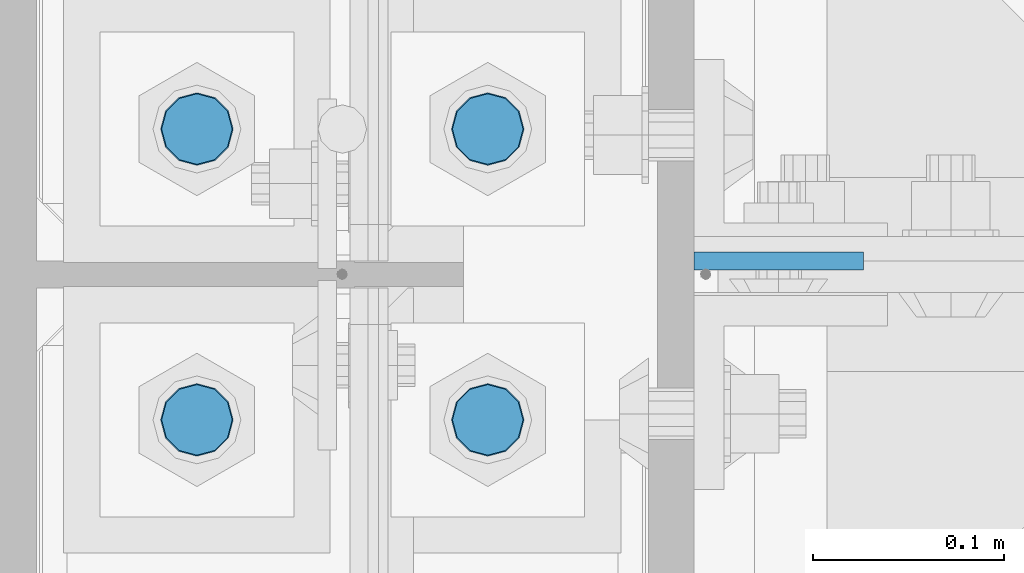
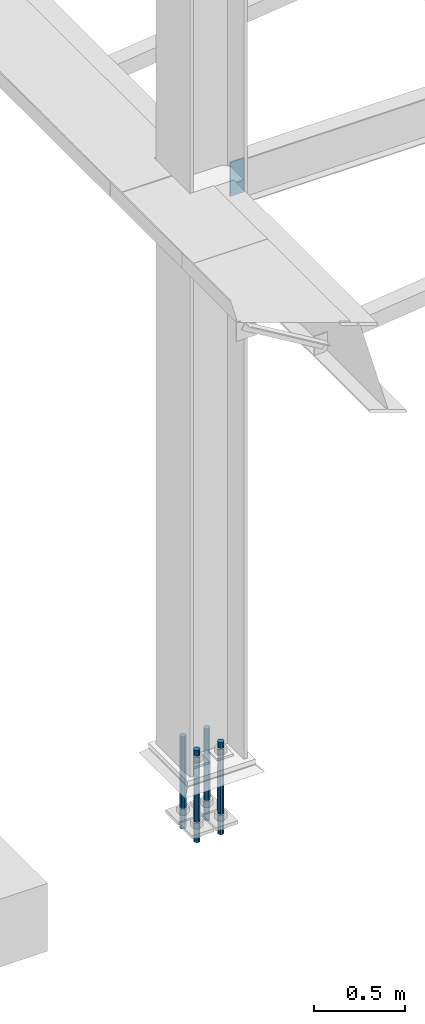
# One storey, part 1513 of 3843: 5 columns, 2 elements without a shape of their own.
"""IFC2X3 building model written with IfcOpenShell, lengths in millimetres."""

from ifc_helpers import new_model, si_unit, frame, origin_with_axes, place, context, subcontext, project, spatial, faceted_brep, material, type_object, element, aggregate, save


model = new_model("IFC2X3")

# Units and contexts
model_context = context("Model", 3, precision=1e-05, world=origin_with_axes())
body_context = subcontext(model_context, "Body", "Model", "MODEL_VIEW")
ifc_project = project(units=[si_unit("LENGTHUNIT", "METRE", prefix="MILLI"), si_unit("AREAUNIT", "SQUARE_METRE"), si_unit("VOLUMEUNIT", "CUBIC_METRE"), si_unit("MASSUNIT", "GRAM", prefix="KILO"), si_unit("TIMEUNIT", "SECOND"), si_unit("PLANEANGLEUNIT", "RADIAN"), si_unit("SOLIDANGLEUNIT", "STERADIAN"), si_unit("THERMODYNAMICTEMPERATUREUNIT", "DEGREE_CELSIUS"), si_unit("LUMINOUSINTENSITYUNIT", "LUMEN")], contexts=[model_context])

# Site, building, storey
site_placement = place(None, origin_with_axes())
site = spatial("IfcSite", under=ifc_project, at=site_placement, CompositionType="ELEMENT")
building_placement = place(site_placement, origin_with_axes())
building = spatial("IfcBuilding", under=site, at=building_placement, Name="Undefined", CompositionType="ELEMENT")
storey_placement = place(building_placement, origin_with_axes())
storey = spatial("IfcBuildingStorey", under=building, at=storey_placement, Name="Undefined", CompositionType="ELEMENT", Elevation=0.0)

# Assembly, column
assembly_1_placement = place(storey_placement, origin_with_axes())
assembly_1 = element("IfcElementAssembly", 1, at=assembly_1_placement, inside=storey, Name="COLUMN", AssemblyPlace="NOTDEFINED", PredefinedType="RIGID_FRAME")
ifc_material_1 = material(Name="STEEL/A572-50")
column_type_1 = type_object("IfcColumnType", PredefinedType="NOTDEFINED")
column_1_placement = place(assembly_1_placement, frame((36804.6, 42209.24375, 33769.3), z_axis=(-1.0, 0.0, 0.0), x_axis=(0.0, 0.0, 1.0)))
column_1 = element("IfcColumn", 2, at=column_1_placement, type_object=column_type_1, material=ifc_material_1, Name="PLATE", context=body_context, shape_type="Brep", body=[
    faceted_brep([(0.0, 4.76249999999709, -44.4500000000007), (0.0, 4.76249999999709, 44.4500000000007), (228.599999999999, 4.76249999999709, 44.4500000000007), (228.599999999999, 4.76249999999709, -44.4500000000007), (0.0, -4.76249999999709, 44.4500000000007), (228.599999999999, -4.76249999999709, 44.4500000000007), (0.0, -4.76249999999709, -44.4500000000007), (228.599999999999, -4.76249999999709, -44.4500000000007)], [[[0, 1, 2, 3]], [[1, 4, 5, 2]], [[4, 6, 7, 5]], [[6, 0, 3, 7]], [[5, 7, 3, 2]], [[6, 4, 1, 0]]]),
])
aggregate(assembly_1, [column_1])

# Assembly, columns
assembly_2_placement = place(storey_placement, origin_with_axes())
assembly_2 = element("IfcElementAssembly", 3, at=assembly_2_placement, inside=storey, Name="TEMPLATE", AssemblyPlace="NOTDEFINED", PredefinedType="RIGID_FRAME")
ifc_material_2 = material(Name="Undefined/F1554-GR.55")
column_type_2 = type_object("IfcColumnType", PredefinedType="NOTDEFINED")
column_2_placement = place(assembly_2_placement, frame((36652.2, 42125.9, 30022.8), z_axis=(1.0, 0.0, 0.0), x_axis=(0.0, 0.0, -1.0)))
column_2 = element("IfcColumn", 4, at=column_2_placement, type_object=column_type_2, material=ifc_material_2, Name="ANCHOR_ROD", context=body_context, shape_type="Brep", body=[
    faceted_brep([(-165.100000000002, -16.0214699700118, 9.25), (-165.100000000002, -9.25, 16.0214699700155), (-165.100000000002, 0.0, 18.5), (-165.100000000002, 9.25, 16.0214699700155), (-165.100000000002, 16.0214699700118, 9.25), (-165.100000000002, 18.5, 0.0), (-165.100000000002, 16.0214699700118, -9.25), (-165.100000000002, 9.25, -16.0214699700155), (-165.100000000002, 0.0, -18.5), (-165.100000000002, -9.25, -16.0214699700155), (-165.100000000002, -16.0214699700118, -9.25), (-165.100000000002, -18.5, 0.0), (0.0, 18.5, 0.0), (0.0, 16.0214699700118, -9.25), (0.0, 9.25, -16.0214699700155), (0.0, 0.0, -18.5), (0.0, -9.25, -16.0214699700155), (0.0, -16.0214699700118, -9.25), (0.0, -18.5, 0.0), (0.0, -16.0214699700118, 9.25), (0.0, -9.25, 16.0214699700155), (0.0, 0.0, 18.5), (0.0, 9.25, 16.0214699700155), (0.0, 16.0214699700118, 9.25), (0.0, -16.4977839420972, 9.52500000000146), (0.0, -9.52500000000146, 16.4977839420972), (0.0, 0.0, 19.0499989999989), (0.0, 9.52500000000146, 16.4977839420972), (0.0, 16.4977839420972, 9.52500000000146), (0.0, 19.0500000000029, 0.0), (0.0, 16.4977839420972, -9.52500000000146), (0.0, 9.52500000000146, -16.4977839420972), (0.0, 0.0, -19.0499989999989), (0.0, -9.52500000000146, -16.4977839420972), (0.0, -16.4977839420972, -9.52500000000146), (0.0, -19.0500000000029, 0.0), (304.799999999999, -19.0499999999993, 0.0), (304.799999999999, -16.4977839420935, 9.52499999999418), (304.799999999999, -9.52500000000146, 16.4977839420899), (304.799987999999, 0.0, 19.0499989999989), (304.799999999999, 9.52500000000146, 16.4977839420899), (304.799999999999, 16.4977839420935, 9.52499999999418), (304.799987792969, 19.0499999999993, 0.0), (304.799999999999, 16.4977839420935, -9.52499999999418), (304.799999999999, 9.52500000000146, -16.4977839420899), (304.799987999999, 0.0, -19.0499989999989), (304.799999999999, -9.52500000000146, -16.4977839420899), (304.799999999999, -16.4977839420935, -9.52499999999418), (304.799999999999, -9.25, 16.0214699700155), (304.799999999999, 0.0, 18.5), (304.799999999999, 9.25, 16.0214699700155), (304.799999999999, 16.0214699700118, 9.25), (304.799999999999, 18.5, 0.0), (304.799999999999, 16.0214699700118, -9.25), (304.799999999999, 9.25, -16.0214699700155), (304.799999999999, 0.0, -18.5), (304.799999999999, -9.25, -16.0214699700155), (304.799999999999, -16.0214699700118, -9.25), (304.799999999999, -18.5, 0.0), (304.799999999999, -16.0214699700118, 9.25), (457.200000000001, -9.25, -16.0214699700155), (457.200000000001, 0.0, -18.5), (457.200000000001, 9.25, -16.0214699700155), (457.200000000001, 16.0214699700118, -9.25), (457.200000000001, 18.5, 0.0), (457.200000000001, 16.0214699700118, 9.25), (457.200000000001, 9.25, 16.0214699700155), (457.200000000001, 0.0, 18.5), (457.200000000001, -9.25, 16.0214699700155), (457.200000000001, -16.0214699700118, 9.25), (457.200000000001, -18.5, 0.0), (457.200000000001, -16.0214699700118, -9.25)], [[[0, 1, 2, 3, 4, 5, 6, 7, 8, 9, 10, 11]], [[6, 5, 12, 13]], [[7, 6, 13, 14]], [[8, 7, 14, 15]], [[9, 8, 15, 16]], [[10, 9, 16, 17]], [[11, 10, 17, 18]], [[0, 11, 18, 19]], [[1, 0, 19, 20]], [[2, 1, 20, 21]], [[3, 2, 21, 22]], [[4, 3, 22, 23]], [[5, 4, 23, 12]], [[24, 25, 26, 27, 28, 29, 30, 31, 32, 33, 34, 35], [22, 21, 20, 19, 18, 17, 16, 15, 14, 13, 12, 23]], [[24, 35, 36, 37]], [[25, 24, 37, 38]], [[26, 25, 38, 39]], [[27, 26, 39, 40]], [[28, 27, 40, 41]], [[29, 28, 41, 42]], [[30, 29, 42, 43]], [[31, 30, 43, 44]], [[32, 31, 44, 45]], [[33, 32, 45, 46]], [[34, 33, 46, 47]], [[35, 34, 47, 36]], [[46, 45, 44, 43, 42, 41, 40, 39, 38, 37, 36, 47], [48, 49, 50, 51, 52, 53, 54, 55, 56, 57, 58, 59]], [[60, 61, 62, 63, 64, 65, 66, 67, 68, 69, 70, 71]], [[68, 67, 49, 48]], [[69, 68, 48, 59]], [[70, 69, 59, 58]], [[71, 70, 58, 57]], [[60, 71, 57, 56]], [[61, 60, 56, 55]], [[62, 61, 55, 54]], [[63, 62, 54, 53]], [[64, 63, 53, 52]], [[65, 64, 52, 51]], [[66, 65, 51, 50]], [[67, 66, 50, 49]]]),
])
column_3_placement = place(assembly_2_placement, frame((36652.2, 42278.3, 30022.8), z_axis=(-1.0, 0.0, 0.0), x_axis=(0.0, 0.0, -1.0)))
column_3 = element("IfcColumn", 5, at=column_3_placement, type_object=column_type_2, material=ifc_material_2, Name="ANCHOR_ROD", context=body_context, shape_type="Brep", body=[
    faceted_brep([(-165.100000000002, -16.0214699700118, 9.25), (-165.100000000002, -9.25, 16.0214699700155), (-165.100000000002, 0.0, 18.5), (-165.100000000002, 9.25, 16.0214699700155), (-165.100000000002, 16.0214699700118, 9.25), (-165.100000000002, 18.5, 0.0), (-165.100000000002, 16.0214699700118, -9.25), (-165.100000000002, 9.25, -16.0214699700155), (-165.100000000002, 0.0, -18.5), (-165.100000000002, -9.25, -16.0214699700155), (-165.100000000002, -16.0214699700118, -9.25), (-165.100000000002, -18.5, 0.0), (0.0, 18.5, 0.0), (0.0, 16.0214699700118, -9.25), (0.0, 9.25, -16.0214699700155), (0.0, 0.0, -18.5), (0.0, -9.25, -16.0214699700155), (0.0, -16.0214699700118, -9.25), (0.0, -18.5, 0.0), (0.0, -16.0214699700118, 9.25), (0.0, -9.25, 16.0214699700155), (0.0, 0.0, 18.5), (0.0, 9.25, 16.0214699700155), (0.0, 16.0214699700118, 9.25), (0.0, -16.4977839420972, 9.52500000000146), (0.0, -9.52500000000146, 16.4977839420972), (0.0, 0.0, 19.0499989999989), (0.0, 9.52500000000146, 16.4977839420972), (0.0, 16.4977839420972, 9.52500000000146), (0.0, 19.0500000000029, 0.0), (0.0, 16.4977839420972, -9.52500000000146), (0.0, 9.52500000000146, -16.4977839420972), (0.0, 0.0, -19.0499989999989), (0.0, -9.52500000000146, -16.4977839420972), (0.0, -16.4977839420972, -9.52500000000146), (0.0, -19.0500000000029, 0.0), (304.799999999999, -19.0499999999993, 0.0), (304.799999999999, -16.4977839420935, 9.52499999999418), (304.799999999999, -9.52500000000146, 16.4977839420899), (304.799987999999, 0.0, 19.0499989999989), (304.799999999999, 9.52500000000146, 16.4977839420899), (304.799999999999, 16.4977839420935, 9.52499999999418), (304.799987792969, 19.0499999999993, 0.0), (304.799999999999, 16.4977839420935, -9.52499999999418), (304.799999999999, 9.52500000000146, -16.4977839420899), (304.799987999999, 0.0, -19.0499989999989), (304.799999999999, -9.52500000000146, -16.4977839420899), (304.799999999999, -16.4977839420935, -9.52499999999418), (304.799999999999, -9.25, 16.0214699700155), (304.799999999999, 0.0, 18.5), (304.799999999999, 9.25, 16.0214699700155), (304.799999999999, 16.0214699700118, 9.25), (304.799999999999, 18.5, 0.0), (304.799999999999, 16.0214699700118, -9.25), (304.799999999999, 9.25, -16.0214699700155), (304.799999999999, 0.0, -18.5), (304.799999999999, -9.25, -16.0214699700155), (304.799999999999, -16.0214699700118, -9.25), (304.799999999999, -18.5, 0.0), (304.799999999999, -16.0214699700118, 9.25), (457.200000000001, -9.25, -16.0214699700155), (457.200000000001, 0.0, -18.5), (457.200000000001, 9.25, -16.0214699700155), (457.200000000001, 16.0214699700118, -9.25), (457.200000000001, 18.5, 0.0), (457.200000000001, 16.0214699700118, 9.25), (457.200000000001, 9.25, 16.0214699700155), (457.200000000001, 0.0, 18.5), (457.200000000001, -9.25, 16.0214699700155), (457.200000000001, -16.0214699700118, 9.25), (457.200000000001, -18.5, 0.0), (457.200000000001, -16.0214699700118, -9.25)], [[[0, 1, 2, 3, 4, 5, 6, 7, 8, 9, 10, 11]], [[6, 5, 12, 13]], [[7, 6, 13, 14]], [[8, 7, 14, 15]], [[9, 8, 15, 16]], [[10, 9, 16, 17]], [[11, 10, 17, 18]], [[0, 11, 18, 19]], [[1, 0, 19, 20]], [[2, 1, 20, 21]], [[3, 2, 21, 22]], [[4, 3, 22, 23]], [[5, 4, 23, 12]], [[24, 25, 26, 27, 28, 29, 30, 31, 32, 33, 34, 35], [22, 21, 20, 19, 18, 17, 16, 15, 14, 13, 12, 23]], [[24, 35, 36, 37]], [[25, 24, 37, 38]], [[26, 25, 38, 39]], [[27, 26, 39, 40]], [[28, 27, 40, 41]], [[29, 28, 41, 42]], [[30, 29, 42, 43]], [[31, 30, 43, 44]], [[32, 31, 44, 45]], [[33, 32, 45, 46]], [[34, 33, 46, 47]], [[35, 34, 47, 36]], [[46, 45, 44, 43, 42, 41, 40, 39, 38, 37, 36, 47], [48, 49, 50, 51, 52, 53, 54, 55, 56, 57, 58, 59]], [[60, 61, 62, 63, 64, 65, 66, 67, 68, 69, 70, 71]], [[68, 67, 49, 48]], [[69, 68, 48, 59]], [[70, 69, 59, 58]], [[71, 70, 58, 57]], [[60, 71, 57, 56]], [[61, 60, 56, 55]], [[62, 61, 55, 54]], [[63, 62, 54, 53]], [[64, 63, 53, 52]], [[65, 64, 52, 51]], [[66, 65, 51, 50]], [[67, 66, 50, 49]]]),
])
column_4_placement = place(assembly_2_placement, frame((36499.8, 42125.9, 30022.8), z_axis=(1.0, 0.0, 0.0), x_axis=(0.0, 0.0, -1.0)))
column_4 = element("IfcColumn", 6, at=column_4_placement, type_object=column_type_2, material=ifc_material_2, Name="ANCHOR_ROD", context=body_context, shape_type="Brep", body=[
    faceted_brep([(-165.100000000002, -16.0214699700118, 9.25), (-165.100000000002, -9.25, 16.0214699700155), (-165.100000000002, 0.0, 18.5), (-165.100000000002, 9.25, 16.0214699700155), (-165.100000000002, 16.0214699700118, 9.25), (-165.100000000002, 18.5, 0.0), (-165.100000000002, 16.0214699700118, -9.25), (-165.100000000002, 9.25, -16.0214699700155), (-165.100000000002, 0.0, -18.5), (-165.100000000002, -9.25, -16.0214699700155), (-165.100000000002, -16.0214699700118, -9.25), (-165.100000000002, -18.5, 0.0), (0.0, 18.5, 0.0), (0.0, 16.0214699700118, -9.25), (0.0, 9.25, -16.0214699700155), (0.0, 0.0, -18.5), (0.0, -9.25, -16.0214699700155), (0.0, -16.0214699700118, -9.25), (0.0, -18.5, 0.0), (0.0, -16.0214699700118, 9.25), (0.0, -9.25, 16.0214699700155), (0.0, 0.0, 18.5), (0.0, 9.25, 16.0214699700155), (0.0, 16.0214699700118, 9.25), (0.0, -16.4977839420972, 9.52500000000146), (0.0, -9.52500000000146, 16.4977839420972), (0.0, 0.0, 19.0499989999989), (0.0, 9.52500000000146, 16.4977839420972), (0.0, 16.4977839420972, 9.52500000000146), (0.0, 19.0500000000029, 0.0), (0.0, 16.4977839420972, -9.52500000000146), (0.0, 9.52500000000146, -16.4977839420972), (0.0, 0.0, -19.0499989999989), (0.0, -9.52500000000146, -16.4977839420972), (0.0, -16.4977839420972, -9.52500000000146), (0.0, -19.0500000000029, 0.0), (304.799999999999, -19.0499999999993, 0.0), (304.799999999999, -16.4977839420935, 9.52499999999418), (304.799999999999, -9.52500000000146, 16.4977839420899), (304.799987999999, 0.0, 19.0499989999989), (304.799999999999, 9.52500000000146, 16.4977839420899), (304.799999999999, 16.4977839420935, 9.52499999999418), (304.799987792969, 19.0499999999993, 0.0), (304.799999999999, 16.4977839420935, -9.52499999999418), (304.799999999999, 9.52500000000146, -16.4977839420899), (304.799987999999, 0.0, -19.0499989999989), (304.799999999999, -9.52500000000146, -16.4977839420899), (304.799999999999, -16.4977839420935, -9.52499999999418), (304.799999999999, -9.25, 16.0214699700155), (304.799999999999, 0.0, 18.5), (304.799999999999, 9.25, 16.0214699700155), (304.799999999999, 16.0214699700118, 9.25), (304.799999999999, 18.5, 0.0), (304.799999999999, 16.0214699700118, -9.25), (304.799999999999, 9.25, -16.0214699700155), (304.799999999999, 0.0, -18.5), (304.799999999999, -9.25, -16.0214699700155), (304.799999999999, -16.0214699700118, -9.25), (304.799999999999, -18.5, 0.0), (304.799999999999, -16.0214699700118, 9.25), (457.200000000001, -9.25, -16.0214699700155), (457.200000000001, 0.0, -18.5), (457.200000000001, 9.25, -16.0214699700155), (457.200000000001, 16.0214699700118, -9.25), (457.200000000001, 18.5, 0.0), (457.200000000001, 16.0214699700118, 9.25), (457.200000000001, 9.25, 16.0214699700155), (457.200000000001, 0.0, 18.5), (457.200000000001, -9.25, 16.0214699700155), (457.200000000001, -16.0214699700118, 9.25), (457.200000000001, -18.5, 0.0), (457.200000000001, -16.0214699700118, -9.25)], [[[0, 1, 2, 3, 4, 5, 6, 7, 8, 9, 10, 11]], [[6, 5, 12, 13]], [[7, 6, 13, 14]], [[8, 7, 14, 15]], [[9, 8, 15, 16]], [[10, 9, 16, 17]], [[11, 10, 17, 18]], [[0, 11, 18, 19]], [[1, 0, 19, 20]], [[2, 1, 20, 21]], [[3, 2, 21, 22]], [[4, 3, 22, 23]], [[5, 4, 23, 12]], [[24, 25, 26, 27, 28, 29, 30, 31, 32, 33, 34, 35], [22, 21, 20, 19, 18, 17, 16, 15, 14, 13, 12, 23]], [[24, 35, 36, 37]], [[25, 24, 37, 38]], [[26, 25, 38, 39]], [[27, 26, 39, 40]], [[28, 27, 40, 41]], [[29, 28, 41, 42]], [[30, 29, 42, 43]], [[31, 30, 43, 44]], [[32, 31, 44, 45]], [[33, 32, 45, 46]], [[34, 33, 46, 47]], [[35, 34, 47, 36]], [[46, 45, 44, 43, 42, 41, 40, 39, 38, 37, 36, 47], [48, 49, 50, 51, 52, 53, 54, 55, 56, 57, 58, 59]], [[60, 61, 62, 63, 64, 65, 66, 67, 68, 69, 70, 71]], [[68, 67, 49, 48]], [[69, 68, 48, 59]], [[70, 69, 59, 58]], [[71, 70, 58, 57]], [[60, 71, 57, 56]], [[61, 60, 56, 55]], [[62, 61, 55, 54]], [[63, 62, 54, 53]], [[64, 63, 53, 52]], [[65, 64, 52, 51]], [[66, 65, 51, 50]], [[67, 66, 50, 49]]]),
])
column_5_placement = place(assembly_2_placement, frame((36499.8, 42278.3, 30022.8), z_axis=(-1.0, 0.0, 0.0), x_axis=(0.0, 0.0, -1.0)))
column_5 = element("IfcColumn", 7, at=column_5_placement, type_object=column_type_2, material=ifc_material_2, Name="ANCHOR_ROD", context=body_context, shape_type="Brep", body=[
    faceted_brep([(-165.100000000002, -16.0214699700118, 9.25), (-165.100000000002, -9.25, 16.0214699700155), (-165.100000000002, 0.0, 18.5), (-165.100000000002, 9.25, 16.0214699700155), (-165.100000000002, 16.0214699700118, 9.25), (-165.100000000002, 18.5, 0.0), (-165.100000000002, 16.0214699700118, -9.25), (-165.100000000002, 9.25, -16.0214699700155), (-165.100000000002, 0.0, -18.5), (-165.100000000002, -9.25, -16.0214699700155), (-165.100000000002, -16.0214699700118, -9.25), (-165.100000000002, -18.5, 0.0), (0.0, 18.5, 0.0), (0.0, 16.0214699700118, -9.25), (0.0, 9.25, -16.0214699700155), (0.0, 0.0, -18.5), (0.0, -9.25, -16.0214699700155), (0.0, -16.0214699700118, -9.25), (0.0, -18.5, 0.0), (0.0, -16.0214699700118, 9.25), (0.0, -9.25, 16.0214699700155), (0.0, 0.0, 18.5), (0.0, 9.25, 16.0214699700155), (0.0, 16.0214699700118, 9.25), (0.0, -16.4977839420972, 9.52500000000146), (0.0, -9.52500000000146, 16.4977839420972), (0.0, 0.0, 19.0499989999989), (0.0, 9.52500000000146, 16.4977839420972), (0.0, 16.4977839420972, 9.52500000000146), (0.0, 19.0500000000029, 0.0), (0.0, 16.4977839420972, -9.52500000000146), (0.0, 9.52500000000146, -16.4977839420972), (0.0, 0.0, -19.0499989999989), (0.0, -9.52500000000146, -16.4977839420972), (0.0, -16.4977839420972, -9.52500000000146), (0.0, -19.0500000000029, 0.0), (304.799999999999, -19.0499999999993, 0.0), (304.799999999999, -16.4977839420935, 9.52499999999418), (304.799999999999, -9.52500000000146, 16.4977839420899), (304.799987999999, 0.0, 19.0499989999989), (304.799999999999, 9.52500000000146, 16.4977839420899), (304.799999999999, 16.4977839420935, 9.52499999999418), (304.799987792969, 19.0499999999993, 0.0), (304.799999999999, 16.4977839420935, -9.52499999999418), (304.799999999999, 9.52500000000146, -16.4977839420899), (304.799987999999, 0.0, -19.0499989999989), (304.799999999999, -9.52500000000146, -16.4977839420899), (304.799999999999, -16.4977839420935, -9.52499999999418), (304.799999999999, -9.25, 16.0214699700155), (304.799999999999, 0.0, 18.5), (304.799999999999, 9.25, 16.0214699700155), (304.799999999999, 16.0214699700118, 9.25), (304.799999999999, 18.5, 0.0), (304.799999999999, 16.0214699700118, -9.25), (304.799999999999, 9.25, -16.0214699700155), (304.799999999999, 0.0, -18.5), (304.799999999999, -9.25, -16.0214699700155), (304.799999999999, -16.0214699700118, -9.25), (304.799999999999, -18.5, 0.0), (304.799999999999, -16.0214699700118, 9.25), (457.200000000001, -9.25, -16.0214699700155), (457.200000000001, 0.0, -18.5), (457.200000000001, 9.25, -16.0214699700155), (457.200000000001, 16.0214699700118, -9.25), (457.200000000001, 18.5, 0.0), (457.200000000001, 16.0214699700118, 9.25), (457.200000000001, 9.25, 16.0214699700155), (457.200000000001, 0.0, 18.5), (457.200000000001, -9.25, 16.0214699700155), (457.200000000001, -16.0214699700118, 9.25), (457.200000000001, -18.5, 0.0), (457.200000000001, -16.0214699700118, -9.25)], [[[0, 1, 2, 3, 4, 5, 6, 7, 8, 9, 10, 11]], [[6, 5, 12, 13]], [[7, 6, 13, 14]], [[8, 7, 14, 15]], [[9, 8, 15, 16]], [[10, 9, 16, 17]], [[11, 10, 17, 18]], [[0, 11, 18, 19]], [[1, 0, 19, 20]], [[2, 1, 20, 21]], [[3, 2, 21, 22]], [[4, 3, 22, 23]], [[5, 4, 23, 12]], [[24, 25, 26, 27, 28, 29, 30, 31, 32, 33, 34, 35], [22, 21, 20, 19, 18, 17, 16, 15, 14, 13, 12, 23]], [[24, 35, 36, 37]], [[25, 24, 37, 38]], [[26, 25, 38, 39]], [[27, 26, 39, 40]], [[28, 27, 40, 41]], [[29, 28, 41, 42]], [[30, 29, 42, 43]], [[31, 30, 43, 44]], [[32, 31, 44, 45]], [[33, 32, 45, 46]], [[34, 33, 46, 47]], [[35, 34, 47, 36]], [[46, 45, 44, 43, 42, 41, 40, 39, 38, 37, 36, 47], [48, 49, 50, 51, 52, 53, 54, 55, 56, 57, 58, 59]], [[60, 61, 62, 63, 64, 65, 66, 67, 68, 69, 70, 71]], [[68, 67, 49, 48]], [[69, 68, 48, 59]], [[70, 69, 59, 58]], [[71, 70, 58, 57]], [[60, 71, 57, 56]], [[61, 60, 56, 55]], [[62, 61, 55, 54]], [[63, 62, 54, 53]], [[64, 63, 53, 52]], [[65, 64, 52, 51]], [[66, 65, 51, 50]], [[67, 66, 50, 49]]]),
])
aggregate(assembly_2, [column_2, column_3, column_4, column_5])

save(model, "model.ifc")
